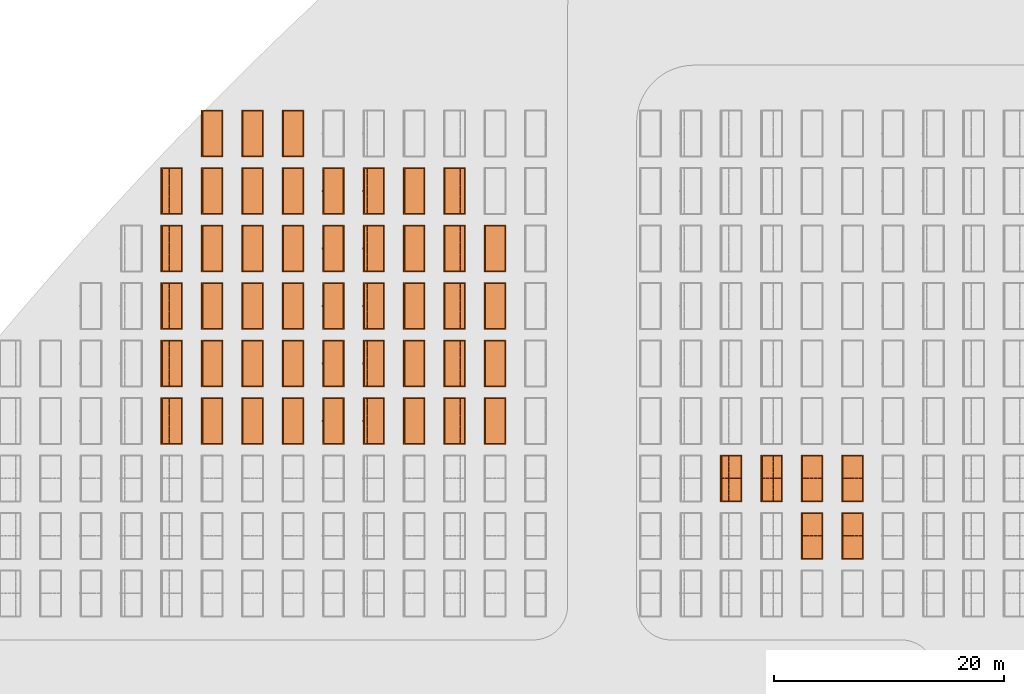
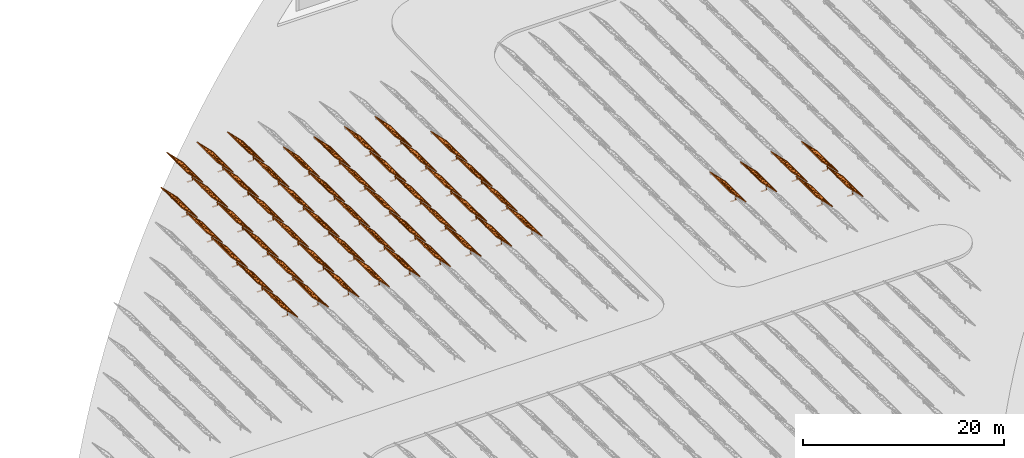
# One storey, part 35 of 39: 53 proxies.
"""IFC2X3 building model written with IfcOpenShell, lengths in millimetres."""

from ifc_helpers import new_model, entity, si_unit, converted_unit, derived_unit, direction, frame, frame_2d, origin, origin_2d_with_axis, place, context, subcontext, project, spatial, polyline, rectangle, outline, extrude, source, transform, mapped, material, material_list, element, save


model = new_model("IFC2X3")

# Units and contexts
model_context = context("Model", 3, precision=1e-06, world=origin(), true_north=direction((2.0, 6.12303176911189e-17, 1.0)))
context_of_model = context(None, 3, precision=1e-06, world=origin(), true_north=direction((2.0, 6.12303176911189e-17, 1.0)))
body_context = subcontext(model_context, "Body", "Model", "MODEL_VIEW")
ifc_project = project(units=[si_unit("LENGTHUNIT", "METRE", prefix="MILLI"), si_unit("AREAUNIT", "SQUARE_METRE", prefix="MILLI"), si_unit("VOLUMEUNIT", "CUBIC_METRE", prefix="MILLI"), converted_unit("PLANEANGLEUNIT", "DEGREE", entity("IfcRatioMeasure", 0.0174532925199433), si_unit("PLANEANGLEUNIT", "RADIAN"), dimensions=[0, 0, 0, 0, 0, 0, 0]), si_unit("MASSUNIT", "GRAM", prefix="KILO"), si_unit("TIMEUNIT", "SECOND"), si_unit("THERMODYNAMICTEMPERATUREUNIT", "KELVIN"), derived_unit("THERMALTRANSMITTANCEUNIT", [(si_unit("MASSUNIT", "GRAM", prefix="KILO"), 1), (si_unit("THERMODYNAMICTEMPERATUREUNIT", "KELVIN"), -1), (si_unit("TIMEUNIT", "SECOND"), -3)]), derived_unit("VOLUMETRICFLOWRATEUNIT", [(si_unit("LENGTHUNIT", "METRE"), 3), (si_unit("TIMEUNIT", "SECOND"), -1)])], contexts=[model_context, context_of_model])

# Site, building, storey
site_placement = place(None, origin())
site = spatial("IfcSite", under=ifc_project, at=site_placement, CompositionType="ELEMENT")
building_placement = place(site_placement, origin())
building = spatial("IfcBuilding", under=site, at=building_placement, CompositionType="ELEMENT")
storey_placement = place(building_placement, frame((0.0, 0.0, 4000.0)))
storey = spatial("IfcBuildingStorey", under=building, at=storey_placement, Name="Level 2", CompositionType="ELEMENT", Elevation=4000.0)

# Proxies
ifc_material_1 = material(Name="Stand-Steel")
ifc_material_2 = material(Name="Aluminium")
ifc_material_3 = material(Name="Glass")
ifc_material_list_1 = material_list([ifc_material_1, ifc_material_2, ifc_material_3])
shared_shape = source(origin(), body_context, "Body", "SweptSolid", [
    extrude(outline(polyline([(-629.526235435404, -220.0), (329.763117717702, -220.0), (329.763117717703, 410.0), (299.763117717703, 410.0), (299.763117717702, -190.0), (-629.526235435404, -190.0), (-629.526235435404, -220.0)])), frame((-190.00003127179, -100.0, 299.763117717707), z_axis=(0.0, 1.0, 0.0), x_axis=(0.0, 0.0, -1.0)), (0.0, 0.0, 1.0), 200.0),
    extrude(rectangle(XDim=20.0000000000001, YDim=200.0, at=frame_2d((0.0, -7.105427357601e-14), x_axis=(0.0, 1.0))), frame((-7.07109908365613, 0.0, 922.21828534124), z_axis=(-0.70710678118654, 0.0, 0.707106781186555), x_axis=(0.0, 1.0, 0.0)), (0.0, 0.0, 1.0), 2600.0),
    extrude(rectangle(XDim=24.9999999999997, YDim=24.9999999999999, at=frame_2d((2.87769807982841e-13, -9.50350909079134e-14), x_axis=(1.0, 0.0))), frame((-1449.56292018118, -1950.0, 2449.57494522722), z_axis=(0.0, 1.0, 0.0), x_axis=(-0.707106781186548, 0.0, -0.707106781186548)), (0.0, 0.0, 1.0), 3900.0),
    extrude(rectangle(XDim=24.9999999999999, YDim=25.0000000000001, at=origin_2d_with_axis()), frame((-1096.0095295879, -1950.0, 2096.02155463395), z_axis=(0.0, 1.0, 0.0), x_axis=(-0.707106781186542, 0.0, -0.707106781186553)), (0.0, 0.0, 1.0), 3900.0),
    extrude(rectangle(XDim=24.9999999999999, YDim=25.0000000000001, at=origin_2d_with_axis()), frame((-742.456138994631, -1950.0, 1742.46816404067), z_axis=(0.0, 1.0, 0.0), x_axis=(-0.707106781186542, 0.0, -0.707106781186553)), (0.0, 0.0, 1.0), 3900.0),
    extrude(rectangle(XDim=25.0, YDim=24.9999999999997, at=frame_2d((-7.19424519957101e-14, 1.19904086659517e-13), x_axis=(1.0, 0.0))), frame((-388.902748401358, -1950.0, 1388.9147734474), z_axis=(0.0, 1.0, 0.0), x_axis=(-0.707106781186545, 0.0, -0.70710678118655)), (0.0, 0.0, 1.0), 3900.0),
    extrude(rectangle(XDim=25.0000000000002, YDim=25.0, at=frame_2d((1.35891298214119e-13, 6.21724893790088e-15), x_axis=(0.0, 1.0))), frame((-35.3553703311048, 1500.0, 1035.35537033109), z_axis=(-0.707106781186544, 0.0, 0.707106781186551), x_axis=(0.0, 1.0, 0.0)), (0.0, 0.0, 1.0), 2440.0),
    extrude(rectangle(XDim=25.0000000000002, YDim=25.0, at=frame_2d((0.0, 1.77635683940025e-15), x_axis=(0.0, 1.0))), frame((-35.3553703311059, 1000.0, 1035.35537033109), z_axis=(-0.707106781186546, 0.0, 0.707106781186549), x_axis=(0.0, 1.0, 0.0)), (0.0, 0.0, 1.0), 2440.0),
    extrude(rectangle(XDim=25.0000000000002, YDim=25.0, at=frame_2d((0.0, 8.43769498715119e-14), x_axis=(0.0, 1.0))), frame((-26.5165355662756, 0.0, 1044.19420509593), z_axis=(-0.707106781186546, 0.0, 0.707106781186549), x_axis=(0.0, -1.0, 0.0)), (0.0, 0.0, 1.0), 2440.0),
    extrude(rectangle(XDim=25.0000000000002, YDim=25.0, at=frame_2d((0.0, 8.88178419700125e-16), x_axis=(0.0, 1.0))), frame((-35.3553703311065, 500.0, 1035.35537033109), z_axis=(-0.707106781186546, 0.0, 0.707106781186549), x_axis=(0.0, 1.0, 0.0)), (0.0, 0.0, 1.0), 2440.0),
    extrude(rectangle(XDim=25.0000000000002, YDim=25.0, at=frame_2d((0.0, 8.88178419700125e-16), x_axis=(0.0, 1.0))), frame((-35.3553703311086, -500.0, 1035.35537033109), z_axis=(-0.707106781186546, 0.0, 0.707106781186549), x_axis=(0.0, 1.0, 0.0)), (0.0, 0.0, 1.0), 2440.0),
    extrude(rectangle(XDim=25.0000000000002, YDim=25.0, at=frame_2d((0.0, 8.88178419700125e-16), x_axis=(0.0, 1.0))), frame((-35.3553703311095, -1000.0, 1035.35537033109), z_axis=(-0.707106781186546, 0.0, 0.707106781186549), x_axis=(0.0, 1.0, 0.0)), (0.0, 0.0, 1.0), 2440.0),
    extrude(rectangle(XDim=25.0000000000002, YDim=25.0, at=frame_2d((1.35891298214119e-13, 1.77635683940025e-15), x_axis=(0.0, 1.0))), frame((-35.3553703311107, -1500.0, 1035.35537033109), z_axis=(-0.707106781186546, 0.0, 0.707106781186549), x_axis=(0.0, 1.0, 0.0)), (0.0, 0.0, 1.0), 2440.0),
    extrude(rectangle(XDim=2400.0, YDim=11.9999999999994, at=frame_2d((-1.13686837721616e-13, 2.02948768901479e-13), x_axis=(1.0, 0.0))), frame((-883.883507754966, -1950.0, 1883.88350775495), z_axis=(0.0, 1.0, 0.0), x_axis=(0.707106781186546, 0.0, -0.707106781186549)), (0.0, 0.0, 1.0), 3900.0),
    extrude(outline(polyline([(-2050.0, -1300.0), (2050.0, -1300.0), (2050.0, 1300.0), (-2050.0, 1300.0), (-2050.0, -1300.0)]), holes=[polyline([(1950.0, -1200.0), (-1950.0, -1200.0), (-1950.0, 1200.0), (1950.0, 1200.0), (1950.0, -1200.0)])]), frame((-919.238846814293, 0.0, 1848.52816869563), z_axis=(0.707106781186554, 0.0, 0.707106781186541), x_axis=(0.0, 1.0, 0.0)), (0.0, 0.0, 1.0), 99.9999999999898),
])
proxy_1_placement = place(storey_placement, frame((-86615.183107613, 650144.680552408, 30.0)))
element("IfcBuildingElementProxy", 1, at=proxy_1_placement, inside=storey, material=ifc_material_list_1, Name="Solar Panel_4000X2500:Solar Panel_4000X2500", ObjectType="Solar Panel_4000X2500", CompositionType="ELEMENT", context=body_context, shape_type="MappedRepresentation", body=[
    mapped(shared_shape, transform((0.0, 0.0, 0.0), scale=1.0)),
])
ifc_material_list_2 = material_list([ifc_material_1, ifc_material_2, ifc_material_3])
proxy_2_placement = place(storey_placement, frame((-83100.1727358832, 650144.680552408, 30.0)))
element("IfcBuildingElementProxy", 2, at=proxy_2_placement, inside=storey, material=ifc_material_list_2, Name="Solar Panel_4000X2500:Solar Panel_4000X2500", ObjectType="Solar Panel_4000X2500", CompositionType="ELEMENT", context=body_context, shape_type="MappedRepresentation", body=[
    mapped(shared_shape, transform((0.0, 0.0, 0.0), scale=1.0)),
])
ifc_material_list_3 = material_list([ifc_material_1, ifc_material_2, ifc_material_3])
proxy_3_placement = place(storey_placement, frame((-93645.2038510726, 655144.680552408, 30.0)))
element("IfcBuildingElementProxy", 3, at=proxy_3_placement, inside=storey, material=ifc_material_list_3, Name="Solar Panel_4000X2500:Solar Panel_4000X2500", ObjectType="Solar Panel_4000X2500", CompositionType="ELEMENT", context=body_context, shape_type="MappedRepresentation", body=[
    mapped(shared_shape, transform((0.0, 0.0, 0.0), scale=1.0)),
])
ifc_material_list_4 = material_list([ifc_material_1, ifc_material_2, ifc_material_3])
proxy_4_placement = place(storey_placement, frame((-90130.1934793428, 655144.680552408, 30.0)))
element("IfcBuildingElementProxy", 4, at=proxy_4_placement, inside=storey, material=ifc_material_list_4, Name="Solar Panel_4000X2500:Solar Panel_4000X2500", ObjectType="Solar Panel_4000X2500", CompositionType="ELEMENT", context=body_context, shape_type="MappedRepresentation", body=[
    mapped(shared_shape, transform((0.0, 0.0, 0.0), scale=1.0)),
])
ifc_material_list_5 = material_list([ifc_material_1, ifc_material_2, ifc_material_3])
proxy_5_placement = place(storey_placement, frame((-86615.183107613, 655144.680552408, 30.0)))
element("IfcBuildingElementProxy", 5, at=proxy_5_placement, inside=storey, material=ifc_material_list_5, Name="Solar Panel_4000X2500:Solar Panel_4000X2500", ObjectType="Solar Panel_4000X2500", CompositionType="ELEMENT", context=body_context, shape_type="MappedRepresentation", body=[
    mapped(shared_shape, transform((0.0, 0.0, 0.0), scale=1.0)),
])
ifc_material_list_6 = material_list([ifc_material_1, ifc_material_2, ifc_material_3])
proxy_6_placement = place(storey_placement, frame((-83100.1727358832, 655144.680552408, 30.0)))
element("IfcBuildingElementProxy", 6, at=proxy_6_placement, inside=storey, material=ifc_material_list_6, Name="Solar Panel_4000X2500:Solar Panel_4000X2500", ObjectType="Solar Panel_4000X2500", CompositionType="ELEMENT", context=body_context, shape_type="MappedRepresentation", body=[
    mapped(shared_shape, transform((0.0, 0.0, 0.0), scale=1.0)),
])
ifc_material_list_7 = material_list([ifc_material_1, ifc_material_2, ifc_material_3])
proxy_7_placement = place(storey_placement, frame((-142310.3179401, 660144.680552408, 30.0)))
element("IfcBuildingElementProxy", 7, at=proxy_7_placement, inside=storey, material=ifc_material_list_7, Name="Solar Panel_4000X2500:Solar Panel_4000X2500", ObjectType="Solar Panel_4000X2500", CompositionType="ELEMENT", context=body_context, shape_type="MappedRepresentation", body=[
    mapped(shared_shape, transform((0.0, 0.0, 0.0), scale=1.0)),
])
ifc_material_list_8 = material_list([ifc_material_1, ifc_material_2, ifc_material_3])
proxy_8_placement = place(storey_placement, frame((-138795.307568371, 660144.680552408, 30.0)))
element("IfcBuildingElementProxy", 8, at=proxy_8_placement, inside=storey, material=ifc_material_list_8, Name="Solar Panel_4000X2500:Solar Panel_4000X2500", ObjectType="Solar Panel_4000X2500", CompositionType="ELEMENT", context=body_context, shape_type="MappedRepresentation", body=[
    mapped(shared_shape, transform((0.0, 0.0, 0.0), scale=1.0)),
])
ifc_material_list_9 = material_list([ifc_material_1, ifc_material_2, ifc_material_3])
proxy_9_placement = place(storey_placement, frame((-135280.297196641, 660144.680552408, 30.0)))
element("IfcBuildingElementProxy", 9, at=proxy_9_placement, inside=storey, material=ifc_material_list_9, Name="Solar Panel_4000X2500:Solar Panel_4000X2500", ObjectType="Solar Panel_4000X2500", CompositionType="ELEMENT", context=body_context, shape_type="MappedRepresentation", body=[
    mapped(shared_shape, transform((0.0, 0.0, 0.0), scale=1.0)),
])
ifc_material_list_10 = material_list([ifc_material_1, ifc_material_2, ifc_material_3])
proxy_10_placement = place(storey_placement, frame((-131765.286824911, 660144.680552408, 30.0)))
element("IfcBuildingElementProxy", 10, at=proxy_10_placement, inside=storey, material=ifc_material_list_10, Name="Solar Panel_4000X2500:Solar Panel_4000X2500", ObjectType="Solar Panel_4000X2500", CompositionType="ELEMENT", context=body_context, shape_type="MappedRepresentation", body=[
    mapped(shared_shape, transform((0.0, 0.0, 0.0), scale=1.0)),
])
ifc_material_list_11 = material_list([ifc_material_1, ifc_material_2, ifc_material_3])
proxy_11_placement = place(storey_placement, frame((-128250.276453181, 660144.680552408, 30.0)))
element("IfcBuildingElementProxy", 11, at=proxy_11_placement, inside=storey, material=ifc_material_list_11, Name="Solar Panel_4000X2500:Solar Panel_4000X2500", ObjectType="Solar Panel_4000X2500", CompositionType="ELEMENT", context=body_context, shape_type="MappedRepresentation", body=[
    mapped(shared_shape, transform((0.0, 0.0, 0.0), scale=1.0)),
])
ifc_material_list_12 = material_list([ifc_material_1, ifc_material_2, ifc_material_3])
proxy_12_placement = place(storey_placement, frame((-124735.266081451, 660144.680552408, 30.0)))
element("IfcBuildingElementProxy", 12, at=proxy_12_placement, inside=storey, material=ifc_material_list_12, Name="Solar Panel_4000X2500:Solar Panel_4000X2500", ObjectType="Solar Panel_4000X2500", CompositionType="ELEMENT", context=body_context, shape_type="MappedRepresentation", body=[
    mapped(shared_shape, transform((0.0, 0.0, 0.0), scale=1.0)),
])
ifc_material_list_13 = material_list([ifc_material_1, ifc_material_2, ifc_material_3])
proxy_13_placement = place(storey_placement, frame((-121220.255709722, 660144.680552408, 30.0)))
element("IfcBuildingElementProxy", 13, at=proxy_13_placement, inside=storey, material=ifc_material_list_13, Name="Solar Panel_4000X2500:Solar Panel_4000X2500", ObjectType="Solar Panel_4000X2500", CompositionType="ELEMENT", context=body_context, shape_type="MappedRepresentation", body=[
    mapped(shared_shape, transform((0.0, 0.0, 0.0), scale=1.0)),
])
ifc_material_list_14 = material_list([ifc_material_1, ifc_material_2, ifc_material_3])
proxy_14_placement = place(storey_placement, frame((-117705.245337992, 660144.680552408, 30.0)))
element("IfcBuildingElementProxy", 14, at=proxy_14_placement, inside=storey, material=ifc_material_list_14, Name="Solar Panel_4000X2500:Solar Panel_4000X2500", ObjectType="Solar Panel_4000X2500", CompositionType="ELEMENT", context=body_context, shape_type="MappedRepresentation", body=[
    mapped(shared_shape, transform((0.0, 0.0, 0.0), scale=1.0)),
])
ifc_material_list_15 = material_list([ifc_material_1, ifc_material_2, ifc_material_3])
proxy_15_placement = place(storey_placement, frame((-142310.3179401, 665144.680552408, 30.0)))
element("IfcBuildingElementProxy", 15, at=proxy_15_placement, inside=storey, material=ifc_material_list_15, Name="Solar Panel_4000X2500:Solar Panel_4000X2500", ObjectType="Solar Panel_4000X2500", CompositionType="ELEMENT", context=body_context, shape_type="MappedRepresentation", body=[
    mapped(shared_shape, transform((0.0, 0.0, 0.0), scale=1.0)),
])
ifc_material_list_16 = material_list([ifc_material_1, ifc_material_2, ifc_material_3])
proxy_16_placement = place(storey_placement, frame((-138795.307568371, 665144.680552408, 30.0)))
element("IfcBuildingElementProxy", 16, at=proxy_16_placement, inside=storey, material=ifc_material_list_16, Name="Solar Panel_4000X2500:Solar Panel_4000X2500", ObjectType="Solar Panel_4000X2500", CompositionType="ELEMENT", context=body_context, shape_type="MappedRepresentation", body=[
    mapped(shared_shape, transform((0.0, 0.0, 0.0), scale=1.0)),
])
ifc_material_list_17 = material_list([ifc_material_1, ifc_material_2, ifc_material_3])
proxy_17_placement = place(storey_placement, frame((-135280.297196641, 665144.680552408, 30.0)))
element("IfcBuildingElementProxy", 17, at=proxy_17_placement, inside=storey, material=ifc_material_list_17, Name="Solar Panel_4000X2500:Solar Panel_4000X2500", ObjectType="Solar Panel_4000X2500", CompositionType="ELEMENT", context=body_context, shape_type="MappedRepresentation", body=[
    mapped(shared_shape, transform((0.0, 0.0, 0.0), scale=1.0)),
])
ifc_material_list_18 = material_list([ifc_material_1, ifc_material_2, ifc_material_3])
proxy_18_placement = place(storey_placement, frame((-131765.286824911, 665144.680552408, 30.0)))
element("IfcBuildingElementProxy", 18, at=proxy_18_placement, inside=storey, material=ifc_material_list_18, Name="Solar Panel_4000X2500:Solar Panel_4000X2500", ObjectType="Solar Panel_4000X2500", CompositionType="ELEMENT", context=body_context, shape_type="MappedRepresentation", body=[
    mapped(shared_shape, transform((0.0, 0.0, 0.0), scale=1.0)),
])
ifc_material_list_19 = material_list([ifc_material_1, ifc_material_2, ifc_material_3])
proxy_19_placement = place(storey_placement, frame((-128250.276453181, 665144.680552408, 30.0)))
element("IfcBuildingElementProxy", 19, at=proxy_19_placement, inside=storey, material=ifc_material_list_19, Name="Solar Panel_4000X2500:Solar Panel_4000X2500", ObjectType="Solar Panel_4000X2500", CompositionType="ELEMENT", context=body_context, shape_type="MappedRepresentation", body=[
    mapped(shared_shape, transform((0.0, 0.0, 0.0), scale=1.0)),
])
ifc_material_list_20 = material_list([ifc_material_1, ifc_material_2, ifc_material_3])
proxy_20_placement = place(storey_placement, frame((-124735.266081451, 665144.680552408, 30.0)))
element("IfcBuildingElementProxy", 20, at=proxy_20_placement, inside=storey, material=ifc_material_list_20, Name="Solar Panel_4000X2500:Solar Panel_4000X2500", ObjectType="Solar Panel_4000X2500", CompositionType="ELEMENT", context=body_context, shape_type="MappedRepresentation", body=[
    mapped(shared_shape, transform((0.0, 0.0, 0.0), scale=1.0)),
])
ifc_material_list_21 = material_list([ifc_material_1, ifc_material_2, ifc_material_3])
proxy_21_placement = place(storey_placement, frame((-121220.255709722, 665144.680552408, 30.0)))
element("IfcBuildingElementProxy", 21, at=proxy_21_placement, inside=storey, material=ifc_material_list_21, Name="Solar Panel_4000X2500:Solar Panel_4000X2500", ObjectType="Solar Panel_4000X2500", CompositionType="ELEMENT", context=body_context, shape_type="MappedRepresentation", body=[
    mapped(shared_shape, transform((0.0, 0.0, 0.0), scale=1.0)),
])
ifc_material_list_22 = material_list([ifc_material_1, ifc_material_2, ifc_material_3])
proxy_22_placement = place(storey_placement, frame((-117705.245337992, 665144.680552408, 30.0)))
element("IfcBuildingElementProxy", 22, at=proxy_22_placement, inside=storey, material=ifc_material_list_22, Name="Solar Panel_4000X2500:Solar Panel_4000X2500", ObjectType="Solar Panel_4000X2500", CompositionType="ELEMENT", context=body_context, shape_type="MappedRepresentation", body=[
    mapped(shared_shape, transform((0.0, 0.0, 0.0), scale=1.0)),
])
ifc_material_list_23 = material_list([ifc_material_1, ifc_material_2, ifc_material_3])
proxy_23_placement = place(storey_placement, frame((-114190.234966262, 660144.680552408, 30.0)))
element("IfcBuildingElementProxy", 23, at=proxy_23_placement, inside=storey, material=ifc_material_list_23, Name="Solar Panel_4000X2500:Solar Panel_4000X2500", ObjectType="Solar Panel_4000X2500", CompositionType="ELEMENT", context=body_context, shape_type="MappedRepresentation", body=[
    mapped(shared_shape, transform((0.0, 0.0, 0.0), scale=1.0)),
])
ifc_material_list_24 = material_list([ifc_material_1, ifc_material_2, ifc_material_3])
proxy_24_placement = place(storey_placement, frame((-114190.234966262, 665144.680552408, 30.0)))
element("IfcBuildingElementProxy", 24, at=proxy_24_placement, inside=storey, material=ifc_material_list_24, Name="Solar Panel_4000X2500:Solar Panel_4000X2500", ObjectType="Solar Panel_4000X2500", CompositionType="ELEMENT", context=body_context, shape_type="MappedRepresentation", body=[
    mapped(shared_shape, transform((0.0, 0.0, 0.0), scale=1.0)),
])
ifc_material_list_25 = material_list([ifc_material_1, ifc_material_2, ifc_material_3])
proxy_25_placement = place(storey_placement, frame((-142310.3179401, 670144.680552408, 30.0)))
element("IfcBuildingElementProxy", 25, at=proxy_25_placement, inside=storey, material=ifc_material_list_25, Name="Solar Panel_4000X2500:Solar Panel_4000X2500", ObjectType="Solar Panel_4000X2500", CompositionType="ELEMENT", context=body_context, shape_type="MappedRepresentation", body=[
    mapped(shared_shape, transform((0.0, 0.0, 0.0), scale=1.0)),
])
ifc_material_list_26 = material_list([ifc_material_1, ifc_material_2, ifc_material_3])
proxy_26_placement = place(storey_placement, frame((-138795.307568371, 670144.680552408, 30.0)))
element("IfcBuildingElementProxy", 26, at=proxy_26_placement, inside=storey, material=ifc_material_list_26, Name="Solar Panel_4000X2500:Solar Panel_4000X2500", ObjectType="Solar Panel_4000X2500", CompositionType="ELEMENT", context=body_context, shape_type="MappedRepresentation", body=[
    mapped(shared_shape, transform((0.0, 0.0, 0.0), scale=1.0)),
])
ifc_material_list_27 = material_list([ifc_material_1, ifc_material_2, ifc_material_3])
proxy_27_placement = place(storey_placement, frame((-135280.297196641, 670144.680552408, 30.0)))
element("IfcBuildingElementProxy", 27, at=proxy_27_placement, inside=storey, material=ifc_material_list_27, Name="Solar Panel_4000X2500:Solar Panel_4000X2500", ObjectType="Solar Panel_4000X2500", CompositionType="ELEMENT", context=body_context, shape_type="MappedRepresentation", body=[
    mapped(shared_shape, transform((0.0, 0.0, 0.0), scale=1.0)),
])
ifc_material_list_28 = material_list([ifc_material_1, ifc_material_2, ifc_material_3])
proxy_28_placement = place(storey_placement, frame((-131765.286824911, 670144.680552408, 30.0)))
element("IfcBuildingElementProxy", 28, at=proxy_28_placement, inside=storey, material=ifc_material_list_28, Name="Solar Panel_4000X2500:Solar Panel_4000X2500", ObjectType="Solar Panel_4000X2500", CompositionType="ELEMENT", context=body_context, shape_type="MappedRepresentation", body=[
    mapped(shared_shape, transform((0.0, 0.0, 0.0), scale=1.0)),
])
ifc_material_list_29 = material_list([ifc_material_1, ifc_material_2, ifc_material_3])
proxy_29_placement = place(storey_placement, frame((-128250.276453181, 670144.680552408, 30.0)))
element("IfcBuildingElementProxy", 29, at=proxy_29_placement, inside=storey, material=ifc_material_list_29, Name="Solar Panel_4000X2500:Solar Panel_4000X2500", ObjectType="Solar Panel_4000X2500", CompositionType="ELEMENT", context=body_context, shape_type="MappedRepresentation", body=[
    mapped(shared_shape, transform((0.0, 0.0, 0.0), scale=1.0)),
])
ifc_material_list_30 = material_list([ifc_material_1, ifc_material_2, ifc_material_3])
proxy_30_placement = place(storey_placement, frame((-124735.266081451, 670144.680552408, 30.0)))
element("IfcBuildingElementProxy", 30, at=proxy_30_placement, inside=storey, material=ifc_material_list_30, Name="Solar Panel_4000X2500:Solar Panel_4000X2500", ObjectType="Solar Panel_4000X2500", CompositionType="ELEMENT", context=body_context, shape_type="MappedRepresentation", body=[
    mapped(shared_shape, transform((0.0, 0.0, 0.0), scale=1.0)),
])
ifc_material_list_31 = material_list([ifc_material_1, ifc_material_2, ifc_material_3])
proxy_31_placement = place(storey_placement, frame((-121220.255709722, 670144.680552408, 30.0)))
element("IfcBuildingElementProxy", 31, at=proxy_31_placement, inside=storey, material=ifc_material_list_31, Name="Solar Panel_4000X2500:Solar Panel_4000X2500", ObjectType="Solar Panel_4000X2500", CompositionType="ELEMENT", context=body_context, shape_type="MappedRepresentation", body=[
    mapped(shared_shape, transform((0.0, 0.0, 0.0), scale=1.0)),
])
ifc_material_list_32 = material_list([ifc_material_1, ifc_material_2, ifc_material_3])
proxy_32_placement = place(storey_placement, frame((-117705.245337992, 670144.680552408, 30.0)))
element("IfcBuildingElementProxy", 32, at=proxy_32_placement, inside=storey, material=ifc_material_list_32, Name="Solar Panel_4000X2500:Solar Panel_4000X2500", ObjectType="Solar Panel_4000X2500", CompositionType="ELEMENT", context=body_context, shape_type="MappedRepresentation", body=[
    mapped(shared_shape, transform((0.0, 0.0, 0.0), scale=1.0)),
])
ifc_material_list_33 = material_list([ifc_material_1, ifc_material_2, ifc_material_3])
proxy_33_placement = place(storey_placement, frame((-142310.3179401, 675144.680552408, 30.0)))
element("IfcBuildingElementProxy", 33, at=proxy_33_placement, inside=storey, material=ifc_material_list_33, Name="Solar Panel_4000X2500:Solar Panel_4000X2500", ObjectType="Solar Panel_4000X2500", CompositionType="ELEMENT", context=body_context, shape_type="MappedRepresentation", body=[
    mapped(shared_shape, transform((0.0, 0.0, 0.0), scale=1.0)),
])
ifc_material_list_34 = material_list([ifc_material_1, ifc_material_2, ifc_material_3])
proxy_34_placement = place(storey_placement, frame((-138795.307568371, 675144.680552408, 30.0)))
element("IfcBuildingElementProxy", 34, at=proxy_34_placement, inside=storey, material=ifc_material_list_34, Name="Solar Panel_4000X2500:Solar Panel_4000X2500", ObjectType="Solar Panel_4000X2500", CompositionType="ELEMENT", context=body_context, shape_type="MappedRepresentation", body=[
    mapped(shared_shape, transform((0.0, 0.0, 0.0), scale=1.0)),
])
ifc_material_list_35 = material_list([ifc_material_1, ifc_material_2, ifc_material_3])
proxy_35_placement = place(storey_placement, frame((-135280.297196641, 675144.680552408, 30.0)))
element("IfcBuildingElementProxy", 35, at=proxy_35_placement, inside=storey, material=ifc_material_list_35, Name="Solar Panel_4000X2500:Solar Panel_4000X2500", ObjectType="Solar Panel_4000X2500", CompositionType="ELEMENT", context=body_context, shape_type="MappedRepresentation", body=[
    mapped(shared_shape, transform((0.0, 0.0, 0.0), scale=1.0)),
])
ifc_material_list_36 = material_list([ifc_material_1, ifc_material_2, ifc_material_3])
proxy_36_placement = place(storey_placement, frame((-131765.286824911, 675144.680552408, 30.0)))
element("IfcBuildingElementProxy", 36, at=proxy_36_placement, inside=storey, material=ifc_material_list_36, Name="Solar Panel_4000X2500:Solar Panel_4000X2500", ObjectType="Solar Panel_4000X2500", CompositionType="ELEMENT", context=body_context, shape_type="MappedRepresentation", body=[
    mapped(shared_shape, transform((0.0, 0.0, 0.0), scale=1.0)),
])
ifc_material_list_37 = material_list([ifc_material_1, ifc_material_2, ifc_material_3])
proxy_37_placement = place(storey_placement, frame((-128250.276453181, 675144.680552408, 30.0)))
element("IfcBuildingElementProxy", 37, at=proxy_37_placement, inside=storey, material=ifc_material_list_37, Name="Solar Panel_4000X2500:Solar Panel_4000X2500", ObjectType="Solar Panel_4000X2500", CompositionType="ELEMENT", context=body_context, shape_type="MappedRepresentation", body=[
    mapped(shared_shape, transform((0.0, 0.0, 0.0), scale=1.0)),
])
ifc_material_list_38 = material_list([ifc_material_1, ifc_material_2, ifc_material_3])
proxy_38_placement = place(storey_placement, frame((-124735.266081451, 675144.680552408, 30.0)))
element("IfcBuildingElementProxy", 38, at=proxy_38_placement, inside=storey, material=ifc_material_list_38, Name="Solar Panel_4000X2500:Solar Panel_4000X2500", ObjectType="Solar Panel_4000X2500", CompositionType="ELEMENT", context=body_context, shape_type="MappedRepresentation", body=[
    mapped(shared_shape, transform((0.0, 0.0, 0.0), scale=1.0)),
])
ifc_material_list_39 = material_list([ifc_material_1, ifc_material_2, ifc_material_3])
proxy_39_placement = place(storey_placement, frame((-121220.255709722, 675144.680552408, 30.0)))
element("IfcBuildingElementProxy", 39, at=proxy_39_placement, inside=storey, material=ifc_material_list_39, Name="Solar Panel_4000X2500:Solar Panel_4000X2500", ObjectType="Solar Panel_4000X2500", CompositionType="ELEMENT", context=body_context, shape_type="MappedRepresentation", body=[
    mapped(shared_shape, transform((0.0, 0.0, 0.0), scale=1.0)),
])
ifc_material_list_40 = material_list([ifc_material_1, ifc_material_2, ifc_material_3])
proxy_40_placement = place(storey_placement, frame((-117705.245337992, 675144.680552408, 30.0)))
element("IfcBuildingElementProxy", 40, at=proxy_40_placement, inside=storey, material=ifc_material_list_40, Name="Solar Panel_4000X2500:Solar Panel_4000X2500", ObjectType="Solar Panel_4000X2500", CompositionType="ELEMENT", context=body_context, shape_type="MappedRepresentation", body=[
    mapped(shared_shape, transform((0.0, 0.0, 0.0), scale=1.0)),
])
ifc_material_list_41 = material_list([ifc_material_1, ifc_material_2, ifc_material_3])
proxy_41_placement = place(storey_placement, frame((-114190.234966262, 670144.680552408, 30.0)))
element("IfcBuildingElementProxy", 41, at=proxy_41_placement, inside=storey, material=ifc_material_list_41, Name="Solar Panel_4000X2500:Solar Panel_4000X2500", ObjectType="Solar Panel_4000X2500", CompositionType="ELEMENT", context=body_context, shape_type="MappedRepresentation", body=[
    mapped(shared_shape, transform((0.0, 0.0, 0.0), scale=1.0)),
])
ifc_material_list_42 = material_list([ifc_material_1, ifc_material_2, ifc_material_3])
proxy_42_placement = place(storey_placement, frame((-114190.234966262, 675144.680552408, 30.0)))
element("IfcBuildingElementProxy", 42, at=proxy_42_placement, inside=storey, material=ifc_material_list_42, Name="Solar Panel_4000X2500:Solar Panel_4000X2500", ObjectType="Solar Panel_4000X2500", CompositionType="ELEMENT", context=body_context, shape_type="MappedRepresentation", body=[
    mapped(shared_shape, transform((0.0, 0.0, 0.0), scale=1.0)),
])
ifc_material_list_43 = material_list([ifc_material_1, ifc_material_2, ifc_material_3])
proxy_43_placement = place(storey_placement, frame((-138795.307568371, 680144.680552408, 30.0)))
element("IfcBuildingElementProxy", 43, at=proxy_43_placement, inside=storey, material=ifc_material_list_43, Name="Solar Panel_4000X2500:Solar Panel_4000X2500", ObjectType="Solar Panel_4000X2500", CompositionType="ELEMENT", context=body_context, shape_type="MappedRepresentation", body=[
    mapped(shared_shape, transform((0.0, 0.0, 0.0), scale=1.0)),
])
ifc_material_list_44 = material_list([ifc_material_1, ifc_material_2, ifc_material_3])
proxy_44_placement = place(storey_placement, frame((-135280.297196641, 680144.680552408, 30.0)))
element("IfcBuildingElementProxy", 44, at=proxy_44_placement, inside=storey, material=ifc_material_list_44, Name="Solar Panel_4000X2500:Solar Panel_4000X2500", ObjectType="Solar Panel_4000X2500", CompositionType="ELEMENT", context=body_context, shape_type="MappedRepresentation", body=[
    mapped(shared_shape, transform((0.0, 0.0, 0.0), scale=1.0)),
])
ifc_material_list_45 = material_list([ifc_material_1, ifc_material_2, ifc_material_3])
proxy_45_placement = place(storey_placement, frame((-131765.286824911, 680144.680552408, 30.0)))
element("IfcBuildingElementProxy", 45, at=proxy_45_placement, inside=storey, material=ifc_material_list_45, Name="Solar Panel_4000X2500:Solar Panel_4000X2500", ObjectType="Solar Panel_4000X2500", CompositionType="ELEMENT", context=body_context, shape_type="MappedRepresentation", body=[
    mapped(shared_shape, transform((0.0, 0.0, 0.0), scale=1.0)),
])
ifc_material_list_46 = material_list([ifc_material_1, ifc_material_2, ifc_material_3])
proxy_46_placement = place(storey_placement, frame((-128250.276453181, 680144.680552408, 30.0)))
element("IfcBuildingElementProxy", 46, at=proxy_46_placement, inside=storey, material=ifc_material_list_46, Name="Solar Panel_4000X2500:Solar Panel_4000X2500", ObjectType="Solar Panel_4000X2500", CompositionType="ELEMENT", context=body_context, shape_type="MappedRepresentation", body=[
    mapped(shared_shape, transform((0.0, 0.0, 0.0), scale=1.0)),
])
ifc_material_list_47 = material_list([ifc_material_1, ifc_material_2, ifc_material_3])
proxy_47_placement = place(storey_placement, frame((-124735.266081451, 680144.680552408, 30.0)))
element("IfcBuildingElementProxy", 47, at=proxy_47_placement, inside=storey, material=ifc_material_list_47, Name="Solar Panel_4000X2500:Solar Panel_4000X2500", ObjectType="Solar Panel_4000X2500", CompositionType="ELEMENT", context=body_context, shape_type="MappedRepresentation", body=[
    mapped(shared_shape, transform((0.0, 0.0, 0.0), scale=1.0)),
])
ifc_material_list_48 = material_list([ifc_material_1, ifc_material_2, ifc_material_3])
proxy_48_placement = place(storey_placement, frame((-121220.255709722, 680144.680552408, 30.0)))
element("IfcBuildingElementProxy", 48, at=proxy_48_placement, inside=storey, material=ifc_material_list_48, Name="Solar Panel_4000X2500:Solar Panel_4000X2500", ObjectType="Solar Panel_4000X2500", CompositionType="ELEMENT", context=body_context, shape_type="MappedRepresentation", body=[
    mapped(shared_shape, transform((0.0, 0.0, 0.0), scale=1.0)),
])
ifc_material_list_49 = material_list([ifc_material_1, ifc_material_2, ifc_material_3])
proxy_49_placement = place(storey_placement, frame((-117705.245337992, 680144.680552408, 30.0)))
element("IfcBuildingElementProxy", 49, at=proxy_49_placement, inside=storey, material=ifc_material_list_49, Name="Solar Panel_4000X2500:Solar Panel_4000X2500", ObjectType="Solar Panel_4000X2500", CompositionType="ELEMENT", context=body_context, shape_type="MappedRepresentation", body=[
    mapped(shared_shape, transform((0.0, 0.0, 0.0), scale=1.0)),
])
ifc_material_list_50 = material_list([ifc_material_1, ifc_material_2, ifc_material_3])
proxy_50_placement = place(storey_placement, frame((-138795.307568371, 685144.680552408, 30.0)))
element("IfcBuildingElementProxy", 50, at=proxy_50_placement, inside=storey, material=ifc_material_list_50, Name="Solar Panel_4000X2500:Solar Panel_4000X2500", ObjectType="Solar Panel_4000X2500", CompositionType="ELEMENT", context=body_context, shape_type="MappedRepresentation", body=[
    mapped(shared_shape, transform((0.0, 0.0, 0.0), scale=1.0)),
])
ifc_material_list_51 = material_list([ifc_material_1, ifc_material_2, ifc_material_3])
proxy_51_placement = place(storey_placement, frame((-135280.297196641, 685144.680552408, 30.0)))
element("IfcBuildingElementProxy", 51, at=proxy_51_placement, inside=storey, material=ifc_material_list_51, Name="Solar Panel_4000X2500:Solar Panel_4000X2500", ObjectType="Solar Panel_4000X2500", CompositionType="ELEMENT", context=body_context, shape_type="MappedRepresentation", body=[
    mapped(shared_shape, transform((0.0, 0.0, 0.0), scale=1.0)),
])
ifc_material_list_52 = material_list([ifc_material_1, ifc_material_2, ifc_material_3])
proxy_52_placement = place(storey_placement, frame((-131765.286824911, 685144.680552408, 30.0)))
element("IfcBuildingElementProxy", 52, at=proxy_52_placement, inside=storey, material=ifc_material_list_52, Name="Solar Panel_4000X2500:Solar Panel_4000X2500", ObjectType="Solar Panel_4000X2500", CompositionType="ELEMENT", context=body_context, shape_type="MappedRepresentation", body=[
    mapped(shared_shape, transform((0.0, 0.0, 0.0), scale=1.0)),
])
ifc_material_list_53 = material_list([ifc_material_1, ifc_material_2, ifc_material_3])
proxy_53_placement = place(storey_placement, frame((-142310.3179401, 680144.680552408, 30.0)))
element("IfcBuildingElementProxy", 53, at=proxy_53_placement, inside=storey, material=ifc_material_list_53, Name="Solar Panel_4000X2500:Solar Panel_4000X2500", ObjectType="Solar Panel_4000X2500", CompositionType="ELEMENT", context=body_context, shape_type="MappedRepresentation", body=[
    mapped(shared_shape, transform((0.0, 0.0, 0.0), scale=1.0)),
])

save(model, "model.ifc")
